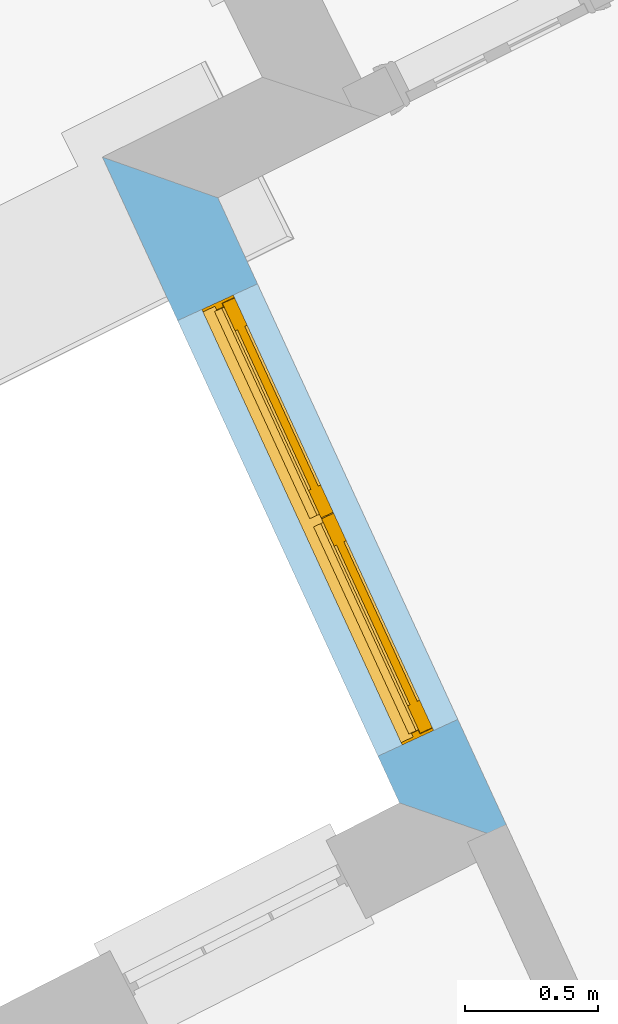
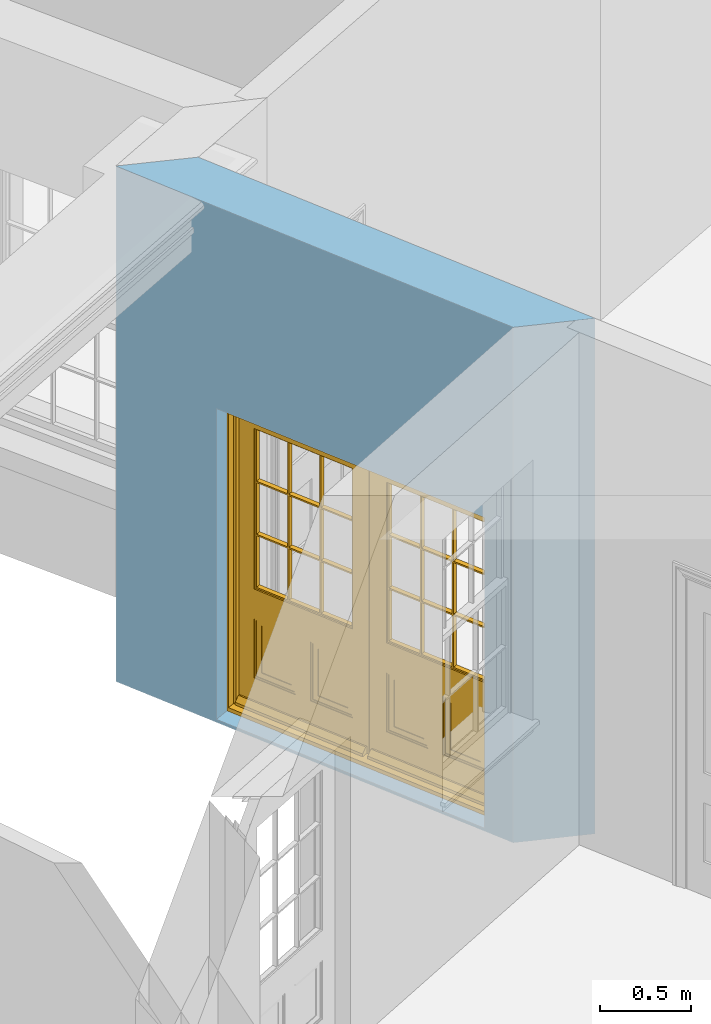
# One storey, part 4 of 10: 1 door, 1 opening, plus 1 element that does not belong to this part.
"""IFC2X3 building model written with IfcOpenShell, lengths in metres."""

from ifc_helpers import new_model, si_unit, frame, origin, place, context, subcontext, project, spatial, polyline, outline, extrude, faceted_brep, material, layer, layer_set, layer_usage, element, fill, save


model = new_model("IFC2X3")

# Units and contexts
model_context = context("Model", 3, world=origin())
body_context = subcontext(model_context, "Body", "Model", "MODEL_VIEW")
ifc_project = project(units=[si_unit("PLANEANGLEUNIT", "RADIAN"), si_unit("MASSUNIT", "GRAM", prefix="KILO"), si_unit("FORCEUNIT", "NEWTON", prefix="KILO"), si_unit("LENGTHUNIT", "METRE")], contexts=[model_context])

# Site, building, storey
site_placement = place(None, origin())
site = spatial("IfcSite", under=ifc_project, at=site_placement, CompositionType="ELEMENT")
building_placement = place(None, origin())
building = spatial("IfcBuilding", under=site, at=building_placement, Name="Building plot-8", CompositionType="ELEMENT")
storey_placement = place(None, origin())
storey = spatial("IfcBuildingStorey", under=building, at=storey_placement, Name="Floor 0", CompositionType="ELEMENT", Elevation=0.0)

# Wall, opening, door
ifc_material = material(Name="Masonry")
ifc_layer = layer(ifc_material, 0.33, ventilated=False)
ifc_layer_set = layer_set([ifc_layer], Name="My Wall")
ifc_layer_usage = layer_usage(ifc_layer_set, "AXIS2", "NEGATIVE", 0.08)
wall_placement = place(storey_placement, origin())
wall = element("IfcWallStandardCase", 1, at=wall_placement, inside=storey, material=ifc_layer_usage, Name="exterior", context=body_context, shape_type="SweptSolid", body=[
    extrude(outline(polyline([(23.9047363507031, 13.0131514717753), (23.4713589357303, 13.1656301723458), (24.5866593596622, 10.7410148794705), (25.0188753029837, 10.5910611684611), (23.9047363507031, 13.0131514717753)])), origin(), (0.0, 0.0, 1.0), 3.45),
])
opening_placement = place(storey_placement, frame((0.0, 0.0, 0.02)))
opening = element("IfcOpeningElement", 2, at=opening_placement, cuts=wall, Name="Opening", ObjectType="Opening", context=body_context, shape_type="SweptSolid", body=[
    extrude(outline(polyline([(23.7536532483681, 12.5519344426335), (24.5058707565745, 10.9166458380295), (24.8056736674186, 11.0545523812007), (24.0534561592121, 12.6898409858047), (23.7536532483681, 12.5519344426335)])), origin(), (0.0, 0.0, 1.0), 2.08),
])
door_placement = place(storey_placement, frame((23.9807766656742, 12.6564090965511, 0.02), z_axis=(0.0, 0.0, 1.0), x_axis=(0.752217508206453, -1.63528860460399, 0.0)))
door = element("IfcDoor", 3, at=door_placement, inside=storey, Name="living outside door", OverallHeight=2.08, OverallWidth=1.8, context=body_context, shape_type="Brep", held_by="IfcProductRepresentation", body=[
    faceted_brep([(0.545, -0.055, 0.265), (0.745, -0.055, 0.265), (0.745, -0.05, 0.265), (0.545, -0.05, 0.265), (0.745, -0.05, 0.58), (0.545, -0.05, 0.58), (0.545, -0.055, 0.58), (0.515, -0.06, 0.235), (0.775, -0.06, 0.235), (0.745, -0.055, 0.58), (0.515, -0.06, 0.61), (0.515, -0.065, 0.235), (0.775, -0.065, 0.235), (0.775, -0.06, 0.61), (0.515, -0.065, 0.61), (0.785, -0.065, 0.225), (0.505, -0.065, 0.225), (0.775, -0.065, 0.61), (0.505, -0.065, 0.62), (0.785, -0.065, 0.62), (0.505, -0.07, 0.225), (0.785, -0.07, 0.225), (0.505, -0.07, 0.62), (0.785, -0.07, 0.62), (0.883, -0.07, 0.075), (0.898, -0.07, 0.075), (0.405, -0.07, 0.62), (0.405, -0.07, 0.225), (0.027, -0.07, 0.075), (0.785, -0.07, 0.82), (0.125, -0.07, 0.82), (0.405, -0.065, 0.62), (0.405, -0.065, 0.225), (0.898, -0.07, 2.068), (0.027, -0.08, 0.075), (0.883, -0.08, 0.075), (0.125, -0.07, 0.225), (0.012, -0.07, 0.075), (0.785, -0.06, 0.82), (0.125, -0.06, 0.82), (0.125, -0.07, 0.62), (0.125, -0.065, 0.62), (0.395, -0.065, 0.61), (0.395, -0.065, 0.235), (0.125, -0.065, 0.225), (0.785, -0.07, 1.895), (0.027, -0.11, 0.045), (0.883, -0.11, 0.045), (0.558333, -0.06, 0.83), (0.351667, -0.06, 0.83), (0.125, -0.07, 1.895), (0.125, -0.06, 1.895), (0.785, -0.06, 1.895), (0.012, -0.07, 2.068), (0.135, -0.065, 0.61), (0.395, -0.06, 0.61), (0.395, -0.06, 0.235), (0.135, -0.065, 0.235), (0.027, -0.11, 0.027), (0.883, -0.11, 0.027), (0.568333, -0.06, 0.83), (0.558333, -0.03, 0.83), (0.351667, -0.03, 0.83), (0.341667, -0.06, 0.83), (0.135, -0.06, 1.185), (0.135, -0.06, 1.53), (0.775, -0.06, 1.53), (0.775, -0.06, 1.185), (0.135, -0.06, 0.61), (0.365, -0.055, 0.58), (0.365, -0.055, 0.265), (0.135, -0.06, 0.235), (0.568333, -0.06, 1.175), (0.558333, -0.06, 1.175), (0.775, -0.06, 0.83), (0.558333, -0.03, 1.175), (0.785, -0.03, 0.82), (0.125, -0.03, 0.82), (0.351667, -0.03, 1.175), (0.351667, -0.06, 1.175), (0.341667, -0.06, 1.175), (0.135, -0.06, 0.83), (0.135, -0.06, 1.175), (0.135, -0.03, 1.185), (0.135, -0.03, 1.53), (0.135, -0.06, 1.54), (0.351667, -0.06, 1.885), (0.558333, -0.06, 1.885), (0.775, -0.03, 1.53), (0.775, -0.03, 1.185), (0.775, -0.06, 1.175), (0.775, -0.06, 1.54), (0.165, -0.055, 0.58), (0.365, -0.05, 0.58), (0.365, -0.05, 0.265), (0.165, -0.055, 0.265), (0.568333, -0.03, 0.83), (0.568333, -0.03, 1.175), (0.568333, -0.06, 1.185), (0.558333, -0.06, 1.185), (0.775, -0.03, 0.83), (0.785, -0.02, 0.82), (0.125, -0.02, 0.82), (0.341667, -0.03, 0.83), (0.341667, -0.03, 1.175), (0.351667, -0.06, 1.185), (0.341667, -0.06, 1.185), (0.135, -0.03, 0.83), (0.341667, -0.03, 1.185), (0.125, -0.03, 1.895), (0.341667, -0.03, 1.53), (0.341667, -0.06, 1.53), (0.135, -0.06, 1.885), (0.341667, -0.06, 1.54), (0.341667, -0.06, 1.885), (0.558333, -0.03, 1.885), (0.351667, -0.03, 1.885), (0.568333, -0.06, 1.885), (0.785, -0.03, 1.895), (0.568333, -0.03, 1.185), (0.568333, -0.06, 1.53), (0.568333, -0.03, 1.53), (0.568333, -0.06, 1.54), (0.775, -0.06, 1.885), (0.165, -0.05, 0.58), (0.165, -0.05, 0.265), (0.775, -0.03, 1.175), (0.558333, -0.06, 1.53), (0.351667, -0.03, 1.185), (0.558333, -0.03, 1.185), (0.505, -0.02, 0.62), (0.405, -0.02, 0.62), (0.125, -0.02, 1.895), (0.785, -0.02, 1.895), (0.351667, -0.06, 1.53), (0.135, -0.03, 1.175), (0.135, -0.03, 1.54), (0.341667, -0.03, 1.54), (0.135, -0.03, 1.885), (0.351667, -0.06, 1.54), (0.558333, -0.03, 1.54), (0.558333, -0.06, 1.54), (0.351667, -0.03, 1.54), (0.775, -0.03, 1.54), (0.568333, -0.03, 1.54), (0.775, -0.03, 1.885), (0.558333, -0.03, 1.53), (0.405, -0.02, 0.225), (0.505, -0.02, 0.225), (0.125, -0.02, 0.62), (0.785, -0.02, 0.62), (0.012, -0.02, 2.068), (0.898, -0.02, 2.068), (0.351667, -0.03, 1.53), (0.341667, -0.03, 1.885), (0.568333, -0.03, 1.885), (0.405, -0.025, 0.225), (0.405, -0.025, 0.62), (0.505, -0.025, 0.62), (0.505, -0.025, 0.225), (0.898, -0.02, 0.027), (0.012, -0.02, 0.027), (0.125, -0.025, 0.62), (0.785, -0.025, 0.62), (0.395, -0.025, 0.235), (0.395, -0.025, 0.61), (0.125, -0.02, 0.225), (0.125, -0.025, 0.225), (0.515, -0.025, 0.61), (0.515, -0.025, 0.235), (0.785, -0.02, 0.225), (0.785, -0.025, 0.225), (0.135, -0.025, 0.61), (0.775, -0.025, 0.61), (0.135, -0.025, 0.235), (0.395, -0.03, 0.235), (0.395, -0.03, 0.61), (0.515, -0.03, 0.61), (0.515, -0.03, 0.235), (0.775, -0.025, 0.235), (0.135, -0.03, 0.61), (0.775, -0.03, 0.61), (0.135, -0.03, 0.235), (0.365, -0.035, 0.265), (0.365, -0.035, 0.58), (0.545, -0.035, 0.58), (0.545, -0.035, 0.265), (0.775, -0.03, 0.235), (0.165, -0.035, 0.58), (0.745, -0.035, 0.58), (0.165, -0.035, 0.265), (0.365, -0.04, 0.58), (0.365, -0.04, 0.265), (0.545, -0.04, 0.58), (0.545, -0.04, 0.265), (0.745, -0.035, 0.265), (0.165, -0.04, 0.58), (0.745, -0.04, 0.58), (0.165, -0.04, 0.265), (0.745, -0.04, 0.265), (1.775, -0.072, 0.025), (0.025, -0.072, 0.025), (0.025, -0.1, 0.025), (1.775, -0.1, 0.025), (1.79, -0.02, 0.025), (0.01, -0.02, 0.025), (1.79, -0.072, 0.025), (1.8, -0.02, 0.0), (0.0, -0.02, 0.0), (0.01, -0.072, 0.025), (1.79, -0.072, 2.07), (1.79, -0.02, 2.07), (1.775, -0.072, 2.055), (1.8, -0.02, 2.08), (0.01, -0.02, 2.07), (0.0, -0.02, 2.08), (0.01, -0.072, 2.07), (0.025, -0.072, 2.055), (0.0, -0.15, 2.08), (1.8, -0.15, 2.08), (0.01, -0.15, 2.07), (1.79, -0.15, 2.07), (0.01, -0.1, 2.07), (1.79, -0.1, 2.07), (0.0, -0.15, 0.0), (1.8, -0.15, 0.0), (0.01, -0.15, 0.025), (1.79, -0.15, 0.025), (0.01, -0.1, 0.025), (0.025, -0.1, 2.055), (1.79, -0.1, 0.025), (1.775, -0.1, 2.055), (0.898, -0.07, 0.027), (0.012, -0.07, 0.027), (0.883, -0.07, 0.027), (0.027, -0.07, 0.027), (1.435, -0.055, 0.265), (1.635, -0.055, 0.265), (1.635, -0.05, 0.265), (1.435, -0.05, 0.265), (1.635, -0.05, 0.58), (1.435, -0.05, 0.58), (1.435, -0.055, 0.58), (1.405, -0.06, 0.235), (1.665, -0.06, 0.235), (1.635, -0.055, 0.58), (1.405, -0.06, 0.61), (1.405, -0.065, 0.235), (1.665, -0.065, 0.235), (1.665, -0.06, 0.61), (1.405, -0.065, 0.61), (1.675, -0.065, 0.225), (1.395, -0.065, 0.225), (1.665, -0.065, 0.61), (1.395, -0.065, 0.62), (1.675, -0.065, 0.62), (1.395, -0.07, 0.225), (1.675, -0.07, 0.225), (1.395, -0.07, 0.62), (1.675, -0.07, 0.62), (1.773, -0.07, 0.075), (1.788, -0.07, 0.075), (1.295, -0.07, 0.62), (1.295, -0.07, 0.225), (0.917, -0.07, 0.075), (1.675, -0.07, 0.82), (1.015, -0.07, 0.82), (1.295, -0.065, 0.62), (1.295, -0.065, 0.225), (1.788, -0.07, 2.068), (0.917, -0.08, 0.075), (1.773, -0.08, 0.075), (1.015, -0.07, 0.225), (0.902, -0.07, 0.075), (1.675, -0.06, 0.82), (1.015, -0.06, 0.82), (1.015, -0.07, 0.62), (1.015, -0.065, 0.62), (1.285, -0.065, 0.61), (1.285, -0.065, 0.235), (1.015, -0.065, 0.225), (1.675, -0.07, 1.895), (0.917, -0.11, 0.045), (1.773, -0.11, 0.045), (1.448333, -0.06, 0.83), (1.241667, -0.06, 0.83), (1.015, -0.07, 1.895), (1.015, -0.06, 1.895), (1.675, -0.06, 1.895), (0.902, -0.07, 2.068), (1.025, -0.065, 0.61), (1.285, -0.06, 0.61), (1.285, -0.06, 0.235), (1.025, -0.065, 0.235), (0.917, -0.11, 0.027), (1.773, -0.11, 0.027), (1.458333, -0.06, 0.83), (1.448333, -0.03, 0.83), (1.241667, -0.03, 0.83), (1.231667, -0.06, 0.83), (1.025, -0.06, 1.185), (1.025, -0.06, 1.53), (1.665, -0.06, 1.53), (1.665, -0.06, 1.185), (1.025, -0.06, 0.61), (1.255, -0.055, 0.58), (1.255, -0.055, 0.265), (1.025, -0.06, 0.235), (1.458333, -0.06, 1.175), (1.448333, -0.06, 1.175), (1.665, -0.06, 0.83), (1.448333, -0.03, 1.175), (1.675, -0.03, 0.82), (1.015, -0.03, 0.82), (1.241667, -0.03, 1.175), (1.241667, -0.06, 1.175), (1.231667, -0.06, 1.175), (1.025, -0.06, 0.83), (1.025, -0.06, 1.175), (1.025, -0.03, 1.185), (1.025, -0.03, 1.53), (1.025, -0.06, 1.54), (1.241667, -0.06, 1.885), (1.448333, -0.06, 1.885), (1.665, -0.03, 1.53), (1.665, -0.03, 1.185), (1.665, -0.06, 1.175), (1.665, -0.06, 1.54), (1.055, -0.055, 0.58), (1.255, -0.05, 0.58), (1.255, -0.05, 0.265), (1.055, -0.055, 0.265), (1.458333, -0.03, 0.83), (1.458333, -0.03, 1.175), (1.458333, -0.06, 1.185), (1.448333, -0.06, 1.185), (1.665, -0.03, 0.83), (1.675, -0.02, 0.82), (1.015, -0.02, 0.82), (1.231667, -0.03, 0.83), (1.231667, -0.03, 1.175), (1.241667, -0.06, 1.185), (1.231667, -0.06, 1.185), (1.025, -0.03, 0.83), (1.231667, -0.03, 1.185), (1.015, -0.03, 1.895), (1.231667, -0.03, 1.53), (1.231667, -0.06, 1.53), (1.025, -0.06, 1.885), (1.231667, -0.06, 1.54), (1.231667, -0.06, 1.885), (1.448333, -0.03, 1.885), (1.241667, -0.03, 1.885), (1.458333, -0.06, 1.885), (1.675, -0.03, 1.895), (1.458333, -0.03, 1.185), (1.458333, -0.06, 1.53), (1.458333, -0.03, 1.53), (1.458333, -0.06, 1.54), (1.665, -0.06, 1.885), (1.055, -0.05, 0.58), (1.055, -0.05, 0.265), (1.665, -0.03, 1.175), (1.448333, -0.06, 1.53), (1.241667, -0.03, 1.185), (1.448333, -0.03, 1.185), (1.395, -0.02, 0.62), (1.295, -0.02, 0.62), (1.015, -0.02, 1.895), (1.675, -0.02, 1.895), (1.241667, -0.06, 1.53), (1.025, -0.03, 1.175), (1.025, -0.03, 1.54), (1.231667, -0.03, 1.54), (1.025, -0.03, 1.885), (1.241667, -0.06, 1.54), (1.448333, -0.03, 1.54), (1.448333, -0.06, 1.54), (1.241667, -0.03, 1.54), (1.665, -0.03, 1.54), (1.458333, -0.03, 1.54), (1.665, -0.03, 1.885), (1.448333, -0.03, 1.53), (1.295, -0.02, 0.225), (1.395, -0.02, 0.225), (1.015, -0.02, 0.62), (1.675, -0.02, 0.62), (0.902, -0.02, 2.068), (1.788, -0.02, 2.068), (1.241667, -0.03, 1.53), (1.231667, -0.03, 1.885), (1.458333, -0.03, 1.885), (1.295, -0.025, 0.225), (1.295, -0.025, 0.62), (1.395, -0.025, 0.62), (1.395, -0.025, 0.225), (1.788, -0.02, 0.027), (0.902, -0.02, 0.027), (1.015, -0.025, 0.62), (1.675, -0.025, 0.62), (1.285, -0.025, 0.235), (1.285, -0.025, 0.61), (1.015, -0.02, 0.225), (1.015, -0.025, 0.225), (1.405, -0.025, 0.61), (1.405, -0.025, 0.235), (1.675, -0.02, 0.225), (1.675, -0.025, 0.225), (1.025, -0.025, 0.61), (1.665, -0.025, 0.61), (1.025, -0.025, 0.235), (1.285, -0.03, 0.235), (1.285, -0.03, 0.61), (1.405, -0.03, 0.61), (1.405, -0.03, 0.235), (1.665, -0.025, 0.235), (1.025, -0.03, 0.61), (1.665, -0.03, 0.61), (1.025, -0.03, 0.235), (1.255, -0.035, 0.265), (1.255, -0.035, 0.58), (1.435, -0.035, 0.58), (1.435, -0.035, 0.265), (1.665, -0.03, 0.235), (1.055, -0.035, 0.58), (1.635, -0.035, 0.58), (1.055, -0.035, 0.265), (1.255, -0.04, 0.58), (1.255, -0.04, 0.265), (1.435, -0.04, 0.58), (1.435, -0.04, 0.265), (1.635, -0.035, 0.265), (1.055, -0.04, 0.58), (1.635, -0.04, 0.58), (1.055, -0.04, 0.265), (1.635, -0.04, 0.265), (1.788, -0.07, 0.027), (0.902, -0.07, 0.027), (1.773, -0.07, 0.027), (0.917, -0.07, 0.027)], [[[0, 1, 2, 3]], [[2, 4, 5, 3]], [[0, 3, 5, 6]], [[1, 0, 7, 8]], [[9, 4, 2, 1]], [[9, 6, 5, 4]], [[0, 6, 10, 7]], [[8, 7, 11, 12]], [[8, 13, 9, 1]], [[13, 10, 6, 9]], [[7, 10, 14, 11]], [[15, 12, 11, 16]], [[12, 17, 13, 8]], [[17, 14, 10, 13]], [[18, 16, 11, 14]], [[15, 19, 17, 12]], [[15, 16, 20, 21]], [[14, 17, 19, 18]], [[16, 18, 22, 20]], [[21, 23, 19, 15]], [[24, 25, 21, 20]], [[23, 22, 18, 19]], [[20, 22, 26, 27]], [[23, 21, 25]], [[28, 24, 20, 27]], [[22, 23, 29]], [[29, 30, 26, 22]], [[27, 26, 31, 32]], [[23, 25, 33, 29]], [[34, 35, 24, 28]], [[28, 27, 36, 37]], [[38, 39, 30, 29]], [[26, 30, 40]], [[26, 40, 41, 31]], [[42, 43, 32, 31]], [[32, 44, 36, 27]], [[33, 45, 29]], [[46, 47, 35, 34]], [[36, 40, 37]], [[39, 38, 48, 49]], [[50, 30, 39, 51]], [[29, 45, 52, 38]], [[53, 37, 40, 30]], [[44, 41, 40, 36]], [[31, 41, 54, 42]], [[43, 42, 55, 56]], [[57, 44, 32, 43]], [[50, 45, 33, 53]], [[47, 46, 58, 59]], [[60, 48, 38]], [[49, 48, 61, 62]], [[49, 63, 39]], [[50, 53, 30]], [[51, 39, 64, 65]], [[45, 50, 51, 52]], [[66, 67, 38, 52]], [[57, 54, 41, 44]], [[42, 54, 68, 55]], [[56, 55, 69, 70]], [[56, 71, 57, 43]], [[60, 72, 73, 48]], [[60, 38, 74]], [[48, 73, 75, 61]], [[76, 77, 62, 61]], [[62, 78, 79, 49]], [[49, 79, 80, 63]], [[63, 81, 39]], [[82, 64, 39]], [[65, 64, 83, 84]], [[85, 51, 65]], [[52, 51, 86, 87]], [[88, 89, 67, 66]], [[90, 38, 67]], [[91, 66, 52]], [[71, 68, 54, 57]], [[55, 68, 92, 69]], [[69, 93, 94, 70]], [[70, 95, 71, 56]], [[96, 97, 72, 60]], [[73, 72, 98, 99]], [[74, 38, 90]], [[100, 96, 60, 74]], [[75, 73, 79, 78]], [[61, 75, 97, 96]], [[101, 102, 77, 76]], [[77, 103, 62]], [[96, 76, 61]], [[103, 104, 78, 62]], [[80, 79, 105, 106]], [[63, 80, 104, 103]], [[81, 63, 103, 107]], [[81, 82, 39]], [[106, 64, 82, 80]], [[106, 108, 83, 64]], [[84, 83, 77, 109]], [[110, 111, 65, 84]], [[112, 51, 85]], [[113, 85, 65, 111]], [[114, 86, 51]], [[115, 87, 86, 116]], [[117, 52, 87]], [[118, 76, 89, 88]], [[119, 98, 67, 89]], [[120, 121, 88, 66]], [[67, 98, 72, 90]], [[91, 122, 120, 66]], [[91, 52, 123]], [[95, 92, 68, 71]], [[69, 92, 124, 93]], [[94, 93, 124, 125]], [[94, 125, 95, 70]], [[72, 97, 126, 90]], [[127, 99, 98, 120]], [[99, 105, 79, 73]], [[74, 90, 126, 100]], [[96, 100, 76]], [[128, 129, 75, 78]], [[97, 75, 129, 119]], [[130, 131, 102, 101]], [[109, 77, 102, 132]], [[133, 101, 76, 118]], [[77, 107, 103]], [[78, 104, 108, 128]], [[111, 106, 105, 134]], [[104, 80, 82, 135]], [[107, 135, 82, 81]], [[110, 108, 106, 111]], [[104, 135, 83, 108]], [[83, 135, 77]], [[136, 84, 109]], [[110, 84, 136, 137]], [[114, 51, 112]], [[85, 136, 138, 112]], [[113, 137, 136, 85]], [[111, 134, 139, 113]], [[86, 114, 113, 139]], [[140, 141, 87, 115]], [[139, 142, 116, 86]], [[109, 118, 115, 116]], [[117, 123, 52]], [[117, 87, 141, 122]], [[126, 89, 76]], [[143, 118, 88]], [[120, 98, 119, 121]], [[119, 89, 126, 97]], [[144, 143, 88, 121]], [[144, 122, 91, 143]], [[127, 120, 122, 141]], [[143, 91, 123, 145]], [[124, 92, 95, 125]], [[146, 129, 99, 127]], [[99, 129, 128, 105]], [[100, 126, 76]], [[121, 119, 129, 146]], [[147, 131, 130, 148]], [[131, 149, 102]], [[130, 101, 150]], [[102, 151, 132]], [[118, 109, 132, 133]], [[101, 133, 152]], [[107, 77, 135]], [[153, 128, 108, 110]], [[134, 105, 128, 153]], [[109, 138, 136]], [[153, 110, 137, 142]], [[154, 114, 112, 138]], [[137, 113, 114, 154]], [[141, 139, 134, 127]], [[141, 140, 142, 139]], [[144, 140, 115, 155]], [[142, 137, 154, 116]], [[155, 115, 118]], [[116, 154, 109]], [[117, 155, 145, 123]], [[122, 144, 155, 117]], [[143, 145, 118]], [[121, 146, 140, 144]], [[146, 127, 134, 153]], [[156, 157, 131, 147]], [[148, 130, 158, 159]], [[148, 160, 161, 147]], [[157, 162, 149, 131]], [[161, 151, 102, 149]], [[101, 152, 160, 150]], [[163, 158, 130, 150]], [[151, 152, 133, 132]], [[154, 138, 109]], [[142, 140, 146, 153]], [[145, 155, 118]], [[157, 156, 164, 165]], [[147, 166, 167, 156]], [[168, 169, 159, 158]], [[170, 148, 159, 171]], [[148, 170, 160]], [[166, 147, 161]], [[172, 162, 157, 165]], [[166, 149, 162, 167]], [[166, 161, 149]], [[150, 160, 170]], [[163, 173, 168, 158]], [[171, 163, 150, 170]], [[174, 164, 156, 167]], [[175, 176, 165, 164]], [[169, 168, 177, 178]], [[171, 159, 169, 179]], [[167, 162, 172, 174]], [[176, 180, 172, 165]], [[179, 173, 163, 171]], [[181, 177, 168, 173]], [[164, 174, 182, 175]], [[183, 184, 176, 175]], [[178, 177, 185, 186]], [[179, 169, 178, 187]], [[174, 172, 180, 182]], [[184, 188, 180, 176]], [[187, 181, 173, 179]], [[189, 185, 177, 181]], [[175, 182, 190, 183]], [[191, 184, 183, 192]], [[185, 193, 194, 186]], [[187, 178, 186, 195]], [[182, 180, 188, 190]], [[191, 196, 188, 184]], [[195, 189, 181, 187]], [[197, 193, 185, 189]], [[183, 190, 198, 192]], [[198, 196, 191, 192]], [[194, 193, 197, 199]], [[195, 186, 194, 199]], [[188, 196, 198, 190]], [[197, 189, 195, 199]], [[200, 201, 202, 203]], [[201, 200, 204, 205]], [[206, 204, 200]], [[204, 207, 208, 205]], [[209, 201, 205]], [[210, 211, 204, 206]], [[206, 200, 212, 210]], [[211, 213, 207, 204]], [[214, 205, 208, 215]], [[216, 217, 201, 209]], [[205, 214, 216, 209]], [[216, 214, 211, 210]], [[210, 212, 217, 216]], [[214, 215, 213, 211]], [[218, 219, 213, 215]], [[219, 218, 220, 221]], [[221, 220, 222, 223]], [[215, 208, 224, 218]], [[225, 224, 208, 207]], [[224, 226, 220, 218]], [[224, 225, 227, 226]], [[219, 225, 207, 213]], [[228, 222, 220, 226]], [[219, 221, 227, 225]], [[226, 227, 203, 202]], [[202, 229, 222, 228]], [[228, 226, 202]], [[227, 221, 223, 230]], [[230, 203, 227]], [[217, 229, 202, 201]], [[231, 223, 222, 229]], [[230, 223, 231, 203]], [[231, 229, 217, 212]], [[212, 200, 203, 231]], [[33, 152, 151, 53]], [[25, 160, 152, 33]], [[161, 37, 53, 151]], [[232, 160, 25]], [[161, 233, 37]], [[160, 232, 234]], [[24, 234, 232, 25]], [[233, 161, 235]], [[37, 233, 235, 28]], [[161, 160, 234, 235]], [[35, 47, 234, 24]], [[28, 235, 46, 34]], [[58, 235, 234, 59]], [[59, 234, 47]], [[58, 46, 235]], [[236, 237, 238, 239]], [[238, 240, 241, 239]], [[236, 239, 241, 242]], [[237, 236, 243, 244]], [[245, 240, 238, 237]], [[245, 242, 241, 240]], [[236, 242, 246, 243]], [[244, 243, 247, 248]], [[244, 249, 245, 237]], [[249, 246, 242, 245]], [[243, 246, 250, 247]], [[251, 248, 247, 252]], [[248, 253, 249, 244]], [[253, 250, 246, 249]], [[254, 252, 247, 250]], [[251, 255, 253, 248]], [[251, 252, 256, 257]], [[250, 253, 255, 254]], [[252, 254, 258, 256]], [[257, 259, 255, 251]], [[260, 261, 257, 256]], [[259, 258, 254, 255]], [[256, 258, 262, 263]], [[259, 257, 261]], [[264, 260, 256, 263]], [[258, 259, 265]], [[265, 266, 262, 258]], [[263, 262, 267, 268]], [[259, 261, 269, 265]], [[270, 271, 260, 264]], [[264, 263, 272, 273]], [[274, 275, 266, 265]], [[262, 266, 276]], [[262, 276, 277, 267]], [[278, 279, 268, 267]], [[268, 280, 272, 263]], [[269, 281, 265]], [[282, 283, 271, 270]], [[272, 276, 273]], [[275, 274, 284, 285]], [[286, 266, 275, 287]], [[265, 281, 288, 274]], [[289, 273, 276, 266]], [[280, 277, 276, 272]], [[267, 277, 290, 278]], [[279, 278, 291, 292]], [[293, 280, 268, 279]], [[286, 281, 269, 289]], [[283, 282, 294, 295]], [[296, 284, 274]], [[285, 284, 297, 298]], [[285, 299, 275]], [[286, 289, 266]], [[287, 275, 300, 301]], [[281, 286, 287, 288]], [[302, 303, 274, 288]], [[293, 290, 277, 280]], [[278, 290, 304, 291]], [[292, 291, 305, 306]], [[292, 307, 293, 279]], [[296, 308, 309, 284]], [[296, 274, 310]], [[284, 309, 311, 297]], [[312, 313, 298, 297]], [[298, 314, 315, 285]], [[285, 315, 316, 299]], [[299, 317, 275]], [[318, 300, 275]], [[301, 300, 319, 320]], [[321, 287, 301]], [[288, 287, 322, 323]], [[324, 325, 303, 302]], [[326, 274, 303]], [[327, 302, 288]], [[307, 304, 290, 293]], [[291, 304, 328, 305]], [[305, 329, 330, 306]], [[306, 331, 307, 292]], [[332, 333, 308, 296]], [[309, 308, 334, 335]], [[310, 274, 326]], [[336, 332, 296, 310]], [[311, 309, 315, 314]], [[297, 311, 333, 332]], [[337, 338, 313, 312]], [[313, 339, 298]], [[332, 312, 297]], [[339, 340, 314, 298]], [[316, 315, 341, 342]], [[299, 316, 340, 339]], [[317, 299, 339, 343]], [[317, 318, 275]], [[342, 300, 318, 316]], [[342, 344, 319, 300]], [[320, 319, 313, 345]], [[346, 347, 301, 320]], [[348, 287, 321]], [[349, 321, 301, 347]], [[350, 322, 287]], [[351, 323, 322, 352]], [[353, 288, 323]], [[354, 312, 325, 324]], [[355, 334, 303, 325]], [[356, 357, 324, 302]], [[303, 334, 308, 326]], [[327, 358, 356, 302]], [[327, 288, 359]], [[331, 328, 304, 307]], [[305, 328, 360, 329]], [[330, 329, 360, 361]], [[330, 361, 331, 306]], [[308, 333, 362, 326]], [[363, 335, 334, 356]], [[335, 341, 315, 309]], [[310, 326, 362, 336]], [[332, 336, 312]], [[364, 365, 311, 314]], [[333, 311, 365, 355]], [[366, 367, 338, 337]], [[345, 313, 338, 368]], [[369, 337, 312, 354]], [[313, 343, 339]], [[314, 340, 344, 364]], [[347, 342, 341, 370]], [[340, 316, 318, 371]], [[343, 371, 318, 317]], [[346, 344, 342, 347]], [[340, 371, 319, 344]], [[319, 371, 313]], [[372, 320, 345]], [[346, 320, 372, 373]], [[350, 287, 348]], [[321, 372, 374, 348]], [[349, 373, 372, 321]], [[347, 370, 375, 349]], [[322, 350, 349, 375]], [[376, 377, 323, 351]], [[375, 378, 352, 322]], [[345, 354, 351, 352]], [[353, 359, 288]], [[353, 323, 377, 358]], [[362, 325, 312]], [[379, 354, 324]], [[356, 334, 355, 357]], [[355, 325, 362, 333]], [[380, 379, 324, 357]], [[380, 358, 327, 379]], [[363, 356, 358, 377]], [[379, 327, 359, 381]], [[360, 328, 331, 361]], [[382, 365, 335, 363]], [[335, 365, 364, 341]], [[336, 362, 312]], [[357, 355, 365, 382]], [[383, 367, 366, 384]], [[367, 385, 338]], [[366, 337, 386]], [[338, 387, 368]], [[354, 345, 368, 369]], [[337, 369, 388]], [[343, 313, 371]], [[389, 364, 344, 346]], [[370, 341, 364, 389]], [[345, 374, 372]], [[389, 346, 373, 378]], [[390, 350, 348, 374]], [[373, 349, 350, 390]], [[377, 375, 370, 363]], [[377, 376, 378, 375]], [[380, 376, 351, 391]], [[378, 373, 390, 352]], [[391, 351, 354]], [[352, 390, 345]], [[353, 391, 381, 359]], [[358, 380, 391, 353]], [[379, 381, 354]], [[357, 382, 376, 380]], [[382, 363, 370, 389]], [[392, 393, 367, 383]], [[384, 366, 394, 395]], [[384, 396, 397, 383]], [[393, 398, 385, 367]], [[397, 387, 338, 385]], [[337, 388, 396, 386]], [[399, 394, 366, 386]], [[387, 388, 369, 368]], [[390, 374, 345]], [[378, 376, 382, 389]], [[381, 391, 354]], [[393, 392, 400, 401]], [[383, 402, 403, 392]], [[404, 405, 395, 394]], [[406, 384, 395, 407]], [[384, 406, 396]], [[402, 383, 397]], [[408, 398, 393, 401]], [[402, 385, 398, 403]], [[402, 397, 385]], [[386, 396, 406]], [[399, 409, 404, 394]], [[407, 399, 386, 406]], [[410, 400, 392, 403]], [[411, 412, 401, 400]], [[405, 404, 413, 414]], [[407, 395, 405, 415]], [[403, 398, 408, 410]], [[412, 416, 408, 401]], [[415, 409, 399, 407]], [[417, 413, 404, 409]], [[400, 410, 418, 411]], [[419, 420, 412, 411]], [[414, 413, 421, 422]], [[415, 405, 414, 423]], [[410, 408, 416, 418]], [[420, 424, 416, 412]], [[423, 417, 409, 415]], [[425, 421, 413, 417]], [[411, 418, 426, 419]], [[427, 420, 419, 428]], [[421, 429, 430, 422]], [[423, 414, 422, 431]], [[418, 416, 424, 426]], [[427, 432, 424, 420]], [[431, 425, 417, 423]], [[433, 429, 421, 425]], [[419, 426, 434, 428]], [[434, 432, 427, 428]], [[430, 429, 433, 435]], [[431, 422, 430, 435]], [[424, 432, 434, 426]], [[433, 425, 431, 435]], [[269, 388, 387, 289]], [[261, 396, 388, 269]], [[397, 273, 289, 387]], [[436, 396, 261]], [[397, 437, 273]], [[396, 436, 438]], [[260, 438, 436, 261]], [[437, 397, 439]], [[273, 437, 439, 264]], [[397, 396, 438, 439]], [[271, 283, 438, 260]], [[264, 439, 282, 270]], [[294, 439, 438, 295]], [[295, 438, 283]], [[294, 282, 439]]]),
])
fill(opening, door)

save(model, "model.ifc")
